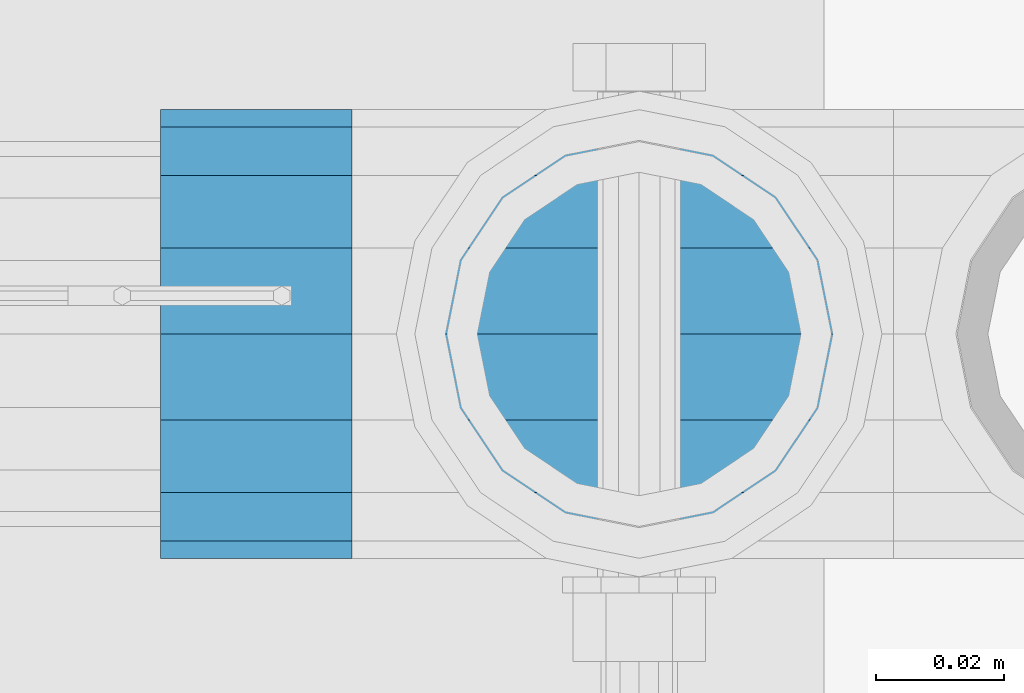
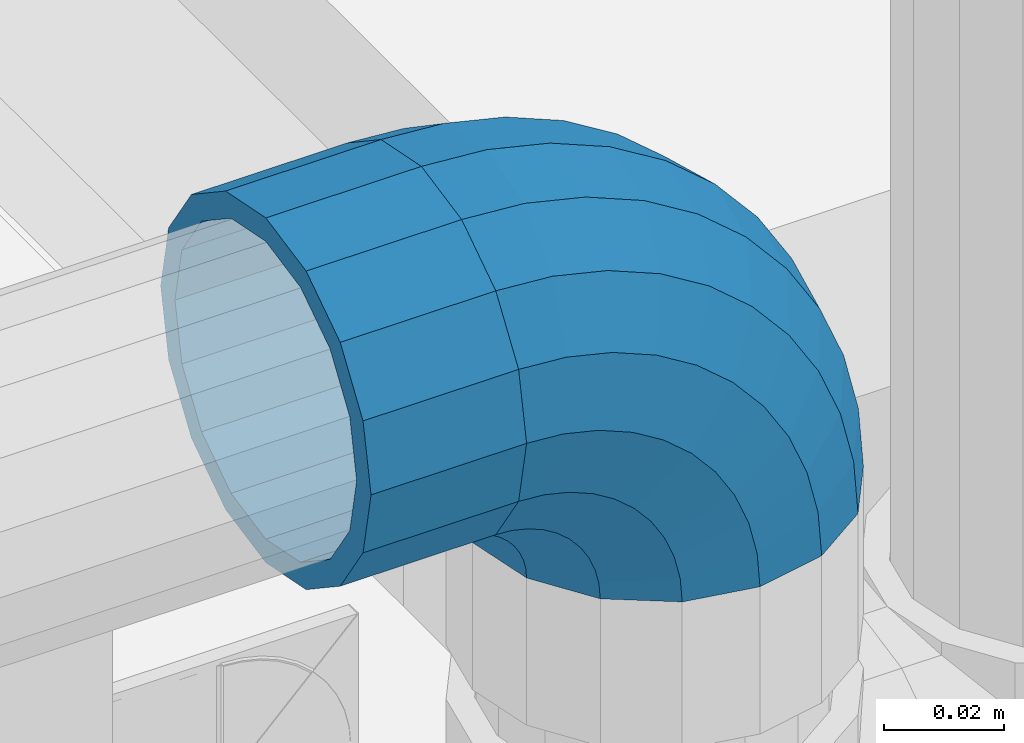
# One storey, part 151 of 219: 1 beam, 1 member.
"""IFC2X3 building model written with IfcOpenShell, lengths in millimetres."""

import ifcopenshell
import ifcopenshell.guid

model = None  # the IFC model being written
_history = None  # IfcOwnerHistory: only IFC2X3 demands one
_inside = {}  # id of a spatial element -> (the spatial element, [elements in it])
_under = {}  # id of a project, library or spatial element -> (it, [spatial elements below it])
_declared = {}  # id of a project -> (the project, [libraries it declares])
_typed = {}  # id of a type object -> (the type object, [elements of that type])
_made_of = {}  # id of a material, layer set ... -> (it, [elements and type objects made of it])


def new_model(schema):
    """Start an empty IFC model of exactly this schema.

    Asked for "IFC4X3", IfcOpenShell would pick the latest addendum, in which some entities
    have other attributes; the version numbers below select the first issue.
    IFC2X3 requires an IfcOwnerHistory on every rooted entity: one is made here for all.
    """
    global model, _history
    if schema == "IFC4X3":
        model = ifcopenshell.file(schema_version=(4, 3, 0, 0))
    else:
        model = ifcopenshell.file(schema=schema)
    _inside.clear()
    _under.clear()
    _declared.clear()
    _typed.clear()
    _made_of.clear()
    _history = None
    if model.schema == "IFC2X3":
        org = make("IfcOrganization", Name="unknown")
        user = make(
            "IfcPersonAndOrganization",
            ThePerson=make("IfcPerson", FamilyName="unknown"),
            TheOrganization=org,
        )
        app = make(
            "IfcApplication",
            ApplicationDeveloper=org,
            Version="unknown",
            ApplicationFullName="unknown",
            ApplicationIdentifier="unknown",
        )
        _history = make(
            "IfcOwnerHistory",
            OwningUser=user,
            OwningApplication=app,
            ChangeAction="ADDED",
            CreationDate=0,
        )
    return model


def make(cls, **values):
    """One entity of the class cls with the attributes given. An attribute that is None is left unset."""
    return model.create_entity(
        cls, **{name: value for name, value in values.items() if value is not None}
    )


def rooted(cls, **values):
    """An entity with a GlobalId (a new one), such as an element, a storey or a relation."""
    return make(cls, GlobalId=ifcopenshell.guid.new(), OwnerHistory=_history, **values)


def si_unit(unit_type, name, prefix=None):
    """IfcSIUnit, for example si_unit("LENGTHUNIT", "METRE", prefix="MILLI")."""
    return make("IfcSIUnit", UnitType=unit_type, Prefix=prefix, Name=name)


def assignment(units):
    """IfcUnitAssignment: the units of a project."""
    return None if units is None else make("IfcUnitAssignment", Units=units)


def point(xyz):
    """IfcCartesianPoint."""
    return None if xyz is None else make("IfcCartesianPoint", Coordinates=xyz)


def direction(xyz):
    """IfcDirection."""
    return None if xyz is None else make("IfcDirection", DirectionRatios=xyz)


def frame(location, z_axis=None, x_axis=None):
    """IfcAxis2Placement3D, a coordinate frame: its origin and axes. An axis left out is left unset."""
    return make(
        "IfcAxis2Placement3D",
        Location=point(location),
        Axis=direction(z_axis),
        RefDirection=direction(x_axis),
    )


def origin_with_axes():
    """The frame at (0, 0, 0) with the z axis (0, 0, 1) and the x axis (1, 0, 0) written out."""
    return frame((0.0, 0.0, 0.0), z_axis=(0.0, 0.0, 1.0), x_axis=(1.0, 0.0, 0.0))


def place(relative_to, where):
    """IfcLocalPlacement: puts the frame where relative to a parent placement (None: the world)."""
    return make(
        "IfcLocalPlacement", PlacementRelTo=relative_to, RelativePlacement=where
    )


def context(
    kind, dimensions, precision=None, world=None, true_north=None, identifier=None
):
    """IfcGeometricRepresentationContext, for example the 3D "Model" context."""
    return make(
        "IfcGeometricRepresentationContext",
        ContextIdentifier=identifier,
        ContextType=kind,
        CoordinateSpaceDimension=dimensions,
        Precision=precision,
        WorldCoordinateSystem=world,
        TrueNorth=true_north,
    )


def subcontext(parent, identifier, kind, view, scale=None):
    """IfcGeometricRepresentationSubContext, for example "Body" below "Model"."""
    return make(
        "IfcGeometricRepresentationSubContext",
        ContextIdentifier=identifier,
        ContextType=kind,
        ParentContext=parent,
        TargetScale=scale,
        TargetView=view,
    )


def project(units=None, contexts=None):
    """IfcProject with its units and contexts."""
    return rooted(
        "IfcProject",
        Name="project",
        RepresentationContexts=contexts,
        UnitsInContext=assignment(units),
    )


def spatial(cls, under=None, at=None, **own):
    """A site, building, storey or space (cls), placed at a placement, below another one or the project."""
    s = rooted(cls, ObjectPlacement=at, **own)
    if under is not None:
        _under.setdefault(under.id(), (under, []))[1].append(s)
    return s


def faces_of(points, faces, orient=None, outer=None):
    """IfcFace entities. A face is a list of loops; a loop is a list of indices into points, from 0.

    orient and outer hold one flag for each loop. By default every Orientation is true, the
    first loop of a face is its IfcFaceOuterBound and the others are IfcFaceBound.
    """
    made = []
    for i, loops in enumerate(faces):
        bounds = []
        for j, loop in enumerate(loops):
            is_outer = j == 0 if outer is None else outer[i][j]
            bounds.append(
                make(
                    "IfcFaceOuterBound" if is_outer else "IfcFaceBound",
                    Bound=make("IfcPolyLoop", Polygon=[points[k] for k in loop]),
                    Orientation=True if orient is None else orient[i][j],
                )
            )
        made.append(make("IfcFace", Bounds=bounds))
    return made


def faceted_brep(points, faces, orient=None, outer=None, voids=None):
    """IfcFacetedBrep: a solid bounded by flat faces; with voids (closed shells), ...WithVoids."""
    shared = [point(p) for p in points]
    hull = make("IfcClosedShell", CfsFaces=faces_of(shared, faces, orient, outer))
    if voids is None:
        return make("IfcFacetedBrep", Outer=hull)
    return make(
        "IfcFacetedBrepWithVoids",
        Outer=hull,
        Voids=[
            make(cls, CfsFaces=faces_of(shared, fs, o, b)) for cls, fs, o, b in voids
        ],
    )


def shape(context_of_items, identifier, shape_type, items):
    """IfcShapeRepresentation: the items that make up one representation, for example the "Body"."""
    return make(
        "IfcShapeRepresentation",
        ContextOfItems=context_of_items,
        RepresentationIdentifier=identifier,
        RepresentationType=shape_type,
        Items=items,
    )


def material(Name=None, Category=None):
    """IfcMaterial."""
    return make("IfcMaterial", Name=Name, Category=Category)


def made_of(thing, what):
    """Note that an element or type object is made of a material, layer set ...; save() writes the relation."""
    if what is not None:
        _made_of.setdefault(what.id(), (what, []))[1].append(thing)
    return thing


def type_object(cls, material=None, **own):
    """A type object (cls), such as IfcWallType, which elements share."""
    return made_of(rooted(cls, **own), material)


def element(
    cls,
    number,
    at=None,
    inside=None,
    cuts=None,
    type_object=None,
    material=None,
    context=None,
    identifier="Body",
    shape_type=None,
    held_by="IfcProductDefinitionShape",
    body=None,
    shapes=None,
    **own,
):
    """One element of the class cls, such as IfcWall. Its Tag is "e" and its number.

    at: its placement. inside: the storey or other place that contains it. cuts: it is an
    opening in that element (IfcRelVoidsElement). A single representation is given by context,
    identifier, shape_type and body (its items); several are given by shapes. held_by: the class
    of the entity that holds the representations. save() writes the other relations.
    """
    e = rooted(cls, Tag="e%d" % number, ObjectPlacement=at, **own)
    if body is not None:
        shapes = [shape(context, identifier, shape_type, body)]
    if shapes is not None:
        e.Representation = make(held_by, Representations=shapes)
    if inside is not None:
        _inside.setdefault(inside.id(), (inside, []))[1].append(e)
    if cuts is not None:
        rooted(
            "IfcRelVoidsElement", RelatingBuildingElement=cuts, RelatedOpeningElement=e
        )
    if type_object is not None:
        _typed.setdefault(type_object.id(), (type_object, []))[1].append(e)
    return made_of(e, material)


def aggregate(whole, parts):
    """IfcRelAggregates: a whole, such as a stair, and the parts it consists of."""
    return rooted("IfcRelAggregates", RelatingObject=whole, RelatedObjects=parts)


def save(model, path):
    """Write the relations noted so far, then the file.

    IfcRelAggregates (storeys below a building ...), IfcRelContainedInSpatialStructure (elements
    in a storey), IfcRelDefinesByType, IfcRelAssociatesMaterial and IfcRelDeclares: one each for
    every whole, place, type object, material and project.
    """
    for whole, parts in _under.values():
        aggregate(whole, parts)
    for where, things in _inside.values():
        rooted(
            "IfcRelContainedInSpatialStructure",
            RelatedElements=things,
            RelatingStructure=where,
        )
    for kind, things in _typed.values():
        rooted("IfcRelDefinesByType", RelatedObjects=things, RelatingType=kind)
    for what, things in _made_of.values():
        rooted("IfcRelAssociatesMaterial", RelatedObjects=things, RelatingMaterial=what)
    for by, libraries in _declared.values():
        rooted("IfcRelDeclares", RelatingContext=by, RelatedDefinitions=libraries)
    model.write(path)


model = new_model("IFC2X3")

# Units and contexts
model_context = context("Model", 3, precision=1e-05, world=origin_with_axes())
body_context = subcontext(model_context, "Body", "Model", "MODEL_VIEW")
ifc_project = project(units=[si_unit("LENGTHUNIT", "METRE", prefix="MILLI"), si_unit("AREAUNIT", "SQUARE_METRE"), si_unit("VOLUMEUNIT", "CUBIC_METRE"), si_unit("MASSUNIT", "GRAM", prefix="KILO"), si_unit("TIMEUNIT", "SECOND"), si_unit("PLANEANGLEUNIT", "RADIAN"), si_unit("SOLIDANGLEUNIT", "STERADIAN"), si_unit("THERMODYNAMICTEMPERATUREUNIT", "DEGREE_CELSIUS"), si_unit("LUMINOUSINTENSITYUNIT", "LUMEN")], contexts=[model_context])

# Site, building, storey
site_placement = place(None, origin_with_axes())
site = spatial("IfcSite", under=ifc_project, at=site_placement, CompositionType="ELEMENT")
building_placement = place(site_placement, origin_with_axes())
building = spatial("IfcBuilding", under=site, at=building_placement, Name="Standard", CompositionType="ELEMENT")
storey_placement = place(building_placement, origin_with_axes())
storey = spatial("IfcBuildingStorey", under=building, at=storey_placement, Name="Undefined", CompositionType="ELEMENT", Elevation=0.0)

# Beam
ifc_material = material(Name="Misc_Undefined")
beam_type = type_object("IfcBeamType", PredefinedType="NOTDEFINED")
beam_placement = place(storey_placement, frame((13386.0, 31664.5, 969.85), z_axis=(0.0, 0.0, 1.0), x_axis=(-1.0, 0.0, 0.0)))
element("IfcBeam", 1, at=beam_placement, inside=storey, type_object=beam_type, material=ifc_material, context=body_context, shape_type="Brep", body=[
    faceted_brep([(0.0, -30.3499999999985, 0.0), (0.0, -28.0397438117179, 11.6144421722802), (30.0, -28.0397438117179, 11.6144421722805), (30.0, -30.3499999999985, 0.0), (0.0, -21.46069080901, 21.4606908090118), (30.0, -21.46069080901, 21.4606908090117), (0.0, -11.614442172282, 28.0397438117179), (30.0, -11.614442172282, 28.0397438117176), (0.0, 0.0, 30.3500000000004), (30.0, 0.0, 30.35), (0.0, 11.614442172282, 28.0397438117179), (30.0, 11.614442172282, 28.0397438117176), (0.0, 21.46069080901, 21.4606908090118), (30.0, 21.46069080901, 21.4606908090117), (0.0, 28.0397438117179, 11.6144421722802), (30.0, 28.0397438117179, 11.6144421722805), (0.0, 30.3499999999985, 0.0), (30.0, 30.3499999999985, 0.0), (0.0, 28.0397438117179, -11.6144421722802), (30.0, 28.0397438117179, -11.6144421722805), (0.0, 21.46069080901, -21.4606908090118), (30.0, 21.46069080901, -21.4606908090117), (0.0, 11.614442172282, -28.0397438117179), (30.0, 11.614442172282, -28.0397438117176), (0.0, 0.0, -30.3500000000004), (30.0, 0.0, -30.35), (0.0, -11.614442172282, -28.0397438117179), (30.0, -11.614442172282, -28.0397438117176), (0.0, -21.46069080901, -21.4606908090118), (30.0, -21.46069080901, -21.4606908090117), (0.0, -28.0397438117179, -11.6144421722802), (30.0, -28.0397438117179, -11.6144421722805), (0.0, -35.1500000000015, 0.0), (0.0, -32.4743655677703, -13.4513226476338), (30.0, -32.4743655677703, -13.4513226476329), (30.0, -35.1500000000015, 0.0), (0.0, -24.8548033587067, -24.8548033587067), (30.0, -24.8548033587067, -24.8548033587072), (0.0, -13.4513226476338, -32.4743655677721), (30.0, -13.4513226476338, -32.4743655677718), (0.0, 0.0, -35.1500000000015), (30.0, 0.0, -35.15), (0.0, 13.4513226476338, -32.4743655677721), (30.0, 13.4513226476338, -32.4743655677718), (0.0, 24.8548033587067, -24.8548033587067), (30.0, 24.8548033587067, -24.8548033587072), (0.0, 32.4743655677703, -13.4513226476338), (30.0, 32.4743655677703, -13.4513226476329), (0.0, 35.1500000000015, 0.0), (30.0, 35.1500000000015, 0.0), (0.0, 32.4743655677703, 13.4513226476338), (30.0, 32.4743655677703, 13.4513226476329), (0.0, 24.8548033587067, 24.8548033587067), (30.0, 24.8548033587067, 24.8548033587072), (0.0, 13.4513226476338, 32.4743655677721), (30.0, 13.4513226476338, 32.4743655677718), (0.0, 0.0, 35.1500000000015), (30.0, 0.0, 35.15), (0.0, -13.4513226476338, 32.4743655677721), (30.0, -13.4513226476338, 32.4743655677718), (0.0, -24.8548033587067, 24.8548033587067), (30.0, -24.8548033587067, 24.8548033587072), (0.0, -32.4743655677703, 13.4513226476338), (30.0, -32.4743655677703, 13.4513226476329)], [[[0, 1, 2, 3]], [[1, 4, 5, 2]], [[4, 6, 7, 5]], [[6, 8, 9, 7]], [[8, 10, 11, 9]], [[10, 12, 13, 11]], [[12, 14, 15, 13]], [[14, 16, 17, 15]], [[16, 18, 19, 17]], [[18, 20, 21, 19]], [[20, 22, 23, 21]], [[22, 24, 25, 23]], [[24, 26, 27, 25]], [[26, 28, 29, 27]], [[28, 30, 31, 29]], [[30, 0, 3, 31]], [[32, 33, 34, 35]], [[33, 36, 37, 34]], [[36, 38, 39, 37]], [[38, 40, 41, 39]], [[40, 42, 43, 41]], [[42, 44, 45, 43]], [[44, 46, 47, 45]], [[46, 48, 49, 47]], [[48, 50, 51, 49]], [[50, 52, 53, 51]], [[52, 54, 55, 53]], [[54, 56, 57, 55]], [[56, 58, 59, 57]], [[58, 60, 61, 59]], [[60, 62, 63, 61]], [[62, 32, 35, 63]], [[37, 39, 41, 43, 45, 47, 49, 51, 53, 55, 57, 59, 61, 63, 35, 34], [5, 7, 9, 11, 13, 15, 17, 19, 21, 23, 25, 27, 29, 31, 3, 2]], [[62, 60, 58, 56, 54, 52, 50, 48, 46, 44, 42, 40, 38, 36, 33, 32], [30, 28, 26, 24, 22, 20, 18, 16, 14, 12, 10, 8, 6, 4, 1, 0]]]),
])

# Member
member_type = type_object("IfcMemberType", PredefinedType="NOTDEFINED")
member_placement = place(storey_placement, frame((13431.0, 31664.5, 924.85), z_axis=(0.707106781186548, 0.0, 0.707106781186547), x_axis=(-0.707106781186548, 0.0, 0.707106781186548)))
element("IfcMember", 2, at=member_placement, inside=storey, type_object=member_type, material=ifc_material, context=body_context, shape_type="Brep", body=[
    faceted_brep([(0.0, -35.1500000000015, 0.0), (9.51152146006825, -32.4743655677703, -9.51152146006643), (13.2759578763371, -32.4743655677703, -6.29638902527404), (5.36946880023152, -35.1500000000015, 4.58595959348168), (17.5749999999971, -24.8548033587067, -17.5749999999971), (19.978755663109, -24.8548033587067, -15.5219987155597), (22.9628441077002, -13.4513226476338, -22.9628441077002), (24.4574219585238, -13.4513226476338, -21.686354032392), (24.8548033587049, 0.0, -24.8548033587031), (26.0301204183133, 0.0, -23.8509877587985), (22.9628441077002, 13.4513226476338, -22.9628441077002), (24.4574219585238, 13.4513226476338, -21.686354032392), (17.5749999999971, 24.8548033587067, -17.5749999999971), (19.978755663109, 24.8548033587067, -15.5219987155597), (9.51152146006825, 32.4743655677703, -9.51152146006643), (13.2759578763371, 32.4743655677703, -6.29638902527404), (0.0, 35.1500000000015, 0.0), (5.36946880023152, 35.1500000000015, 4.58595959348168), (-9.51152146007189, 32.4743655677703, 9.51152146007371), (-2.53702027587497, 32.4743655677703, 15.4683082122356), (-17.5750000000007, 24.8548033587067, 17.5750000000025), (-9.23981806264692, 24.8548033587067, 24.6939179025212), (-22.9628441077039, 13.4513226476338, 22.9628441077057), (-13.718484358059, 13.4513226476338, 30.8582732193536), (-24.8548033587085, 0.0, 24.8548033587103), (-15.2911828178485, 0.0, 33.02290694576), (-22.9628441077039, -13.4513226476338, 22.9628441077057), (-13.718484358059, -13.4513226476338, 30.8582732193536), (-17.5750000000007, -24.8548033587067, 17.5750000000025), (-9.23981806264692, -24.8548033587067, 24.6939179025212), (-9.51152146007189, -32.4743655677703, 9.51152146007371), (-2.53702027587497, -32.4743655677703, 15.4683082122356), (0.0, -30.3499999999985, 0.0), (-8.21265081971978, -28.0397438117179, 8.2126508197216), (-1.45732902223881, -28.0397438117179, 13.9822406910407), (5.36946880023152, -30.3499999999985, 4.58595959348168), (-15.1750000000011, -21.46069080901, 15.1750000000029), (-7.24480876131474, -21.46069080901, 21.9480231689977), (-19.8270929920018, -11.614442172282, 19.8270929920018), (-11.1118790903547, -11.614442172282, 27.2705888550809), (-21.4606908090136, 0.0, 21.4606908090154), (-12.4698136068446, 0.0, 29.1396253727617), (-19.8270929920018, 11.614442172282, 19.8270929920018), (-11.1118790903547, 11.614442172282, 27.2705888550809), (-15.1750000000011, 21.46069080901, 15.1750000000029), (-7.24480876131474, 21.46069080901, 21.9480231689977), (-8.21265081971978, 28.0397438117179, 8.2126508197216), (-1.45732902223881, 28.0397438117179, 13.9822406910407), (0.0, 30.3499999999985, 0.0), (5.36946880023152, 30.3499999999985, 4.58595959348168), (8.21265081971615, 28.0397438117179, -8.21265081971433), (12.1962666227028, 28.0397438117179, -4.81032150407918), (15.1749999999975, 21.46069080901, -15.1749999999975), (17.9837463617769, 21.46069080901, -12.7761039820361), (19.8270929919981, 11.614442172282, -19.8270929919963), (21.8508166908196, 11.614442172282, -18.0986696681193), (21.46069080901, 0.0, -21.4606908090082), (23.2087512073094, 0.0, -19.9677061858001), (19.8270929919981, -11.614442172282, -19.8270929919963), (21.8508166908196, -11.614442172282, -18.0986696681193), (15.1749999999975, -21.46069080901, -15.1749999999975), (17.9837463617769, -21.46069080901, -12.7761039820361), (8.21265081971615, -28.0397438117179, -8.21265081971433), (12.1962666227028, -28.0397438117179, -4.81032150407918), (17.4970053560701, -32.4743655677703, -3.70972780291777), (11.3902326651123, -35.1500000000015, 8.27548843508521), (22.6740772628609, -24.8548033587067, -13.870303514941), (26.1332861179508, -13.4513226476338, -20.6593831546797), (27.3479987309584, 0.0, -23.0433908901377), (26.1332861179508, 13.4513226476338, -20.6593831546797), (22.6740772628609, 24.8548033587067, -13.870303514941), (17.4970053560701, 32.4743655677703, -3.70972780291777), (11.3902326651123, 35.1500000000015, 8.27548843508521), (5.28345997415727, 32.4743655677703, 20.2607046730882), (0.106388067365515, 24.8548033587067, 30.4212803851115), (-3.35282078772343, 13.4513226476338, 37.2103600248465), (-4.56753340073192, 0.0, 39.5943677603063), (-3.35282078772343, -13.4513226476338, 37.2103600248465), (0.106388067365515, -24.8548033587067, 30.4212803851115), (5.28345997415727, -32.4743655677703, 20.2607046730882), (6.11738625912403, -28.0397438117179, 18.6240321853929), (11.3902326651123, -30.3499999999985, 8.27548843508521), (1.64728291997471, -21.46069080901, 27.3971039595035), (-1.33954464053568, -11.614442172282, 33.2590831078942), (-2.38837900198178, 0.0, 35.3175364442013), (-1.33954464053568, 11.614442172282, 33.2590831078942), (1.64728291997471, 21.46069080901, 27.3971039595035), (6.11738625912403, 28.0397438117179, 18.6240321853929), (11.3902326651123, 30.3499999999985, 8.27548843508521), (16.6630790711033, 28.0397438117179, -2.07305531522616), (21.1331824102526, 21.46069080901, -10.8461270893331), (24.1200099707648, 11.614442172282, -16.7081062377274), (25.1688443322091, 0.0, -18.7665595740327), (24.1200099707648, -11.614442172282, -16.7081062377274), (21.1331824102526, -21.46069080901, -10.8461270893331), (16.6630790711033, -28.0397438117179, -2.07305531522616), (22.0707277014599, -32.4743655677703, -1.81522997692991), (17.9140404065201, -35.1500000000015, 10.9777380798878), (25.5945970362091, -24.8548033587067, -12.6605846156435), (27.9491712485078, -13.4513226476338, -19.9072189058916), (28.7759877588005, 0.0, -22.4518984678853), (27.9491712485078, 13.4513226476338, -19.9072189058916), (25.5945970362091, 24.8548033587067, -12.6605846156435), (22.0707277014599, 32.4743655677703, -1.81522997692991), (17.9140404065201, 35.1500000000015, 10.9777380798878), (13.7573531115804, 32.4743655677703, 23.7707061367109), (10.2334837768312, 24.8548033587067, 34.6160607754227), (7.8789095645343, 13.4513226476338, 41.8626950656708), (7.0520930542416, 0.0, 44.4073746276645), (7.8789095645343, -13.4513226476338, 41.8626950656708), (10.2334837768312, -24.8548033587067, 34.6160607754227), (13.7573531115804, -32.4743655677703, 23.7707061367109), (14.3249803951003, -28.0397438117179, 22.023728990971), (17.9140404065201, -30.3499999999985, 10.9777380798878), (11.28232223551, -21.46069080901, 31.3880679179965), (9.24928305077992, -11.614442172282, 37.6451191472715), (8.53537462724125, 0.0, 39.8423033494473), (9.24928305077992, 11.614442172282, 37.6451191472715), (11.28232223551, 21.46069080901, 31.3880679179965), (14.3249803951003, 28.0397438117179, 22.023728990971), (17.9140404065201, 30.3499999999985, 10.9777380798878), (21.5031004179409, 28.0397438117179, -0.0682528311899659), (24.5457585775303, 21.46069080901, -9.43259175821731), (26.5787977622622, 11.614442172282, -15.6896429874923), (27.2927061857999, 0.0, -17.8868271896681), (26.5787977622622, -11.614442172282, -15.6896429874923), (24.5457585775303, -21.46069080901, -9.43259175821731), (21.5031004179409, -28.0397438117179, -0.0682528311899659), (26.8845046890492, -32.4743655677703, -0.659544371261291), (24.7802542265817, -35.1500000000015, 12.6261701733893), (28.6684020936827, -24.8548033587067, -11.9226293117899), (29.8603642316984, -13.4513226476338, -19.4483820661226), (30.2789256727474, 0.0, -22.0910749985305), (29.8603642316984, 13.4513226476338, -19.4483820661226), (28.6684020936827, 24.8548033587067, -11.9226293117899), (26.8845046890492, 32.4743655677703, -0.659544371261291), (24.7802542265817, 35.1500000000015, 12.6261701733893), (22.676003764117, 32.4743655677703, 25.9118847180398), (20.8921063594835, 24.8548033587067, 37.1749696585684), (19.7001442214678, 13.4513226476338, 44.7007224129011), (19.2815827804179, 0.0, 47.343415345309), (19.7001442214678, -13.4513226476338, 44.7007224129011), (20.8921063594835, -24.8548033587067, 37.1749696585684), (22.676003764117, -32.4743655677703, 25.9118847180398), (22.963355178621, -28.0397438117179, 24.0976192894668), (24.7802542265817, -30.3499999999985, 12.6261701733893), (21.4230625404825, -21.46069080901, 33.8226442665673), (20.3938719035323, -11.614442172282, 40.3206982094962), (20.032468212612, 0.0, 42.6025113104515), (20.3938719035323, 11.614442172282, 40.3206982094962), (21.4230625404825, 21.46069080901, 33.8226442665673), (22.963355178621, 28.0397438117179, 24.0976192894668), (24.7802542265817, 30.3499999999985, 12.6261701733893), (26.5971532745452, 28.0397438117179, 1.15472105731169), (28.1374459126837, 21.46069080901, -8.57030391978697), (29.1666365496339, 11.614442172282, -15.0683578627177), (29.5280402405542, 0.0, -17.350170963673), (29.1666365496339, -11.614442172282, -15.0683578627177), (28.1374459126837, -21.46069080901, -8.57030391978697), (26.5971532745434, -28.0397438117179, 1.15472105731169), (31.8198051533936, -32.4743655677703, -0.271127801024704), (31.8198051533927, -35.1500000000015, 13.1801948466091), (31.8198051533927, -24.8548033587067, -11.6746085121013), (31.8198051533927, -13.4513226476338, -19.2941707211648), (31.8198051533918, 0.0, -21.9698051533924), (31.8198051533927, 13.4513226476338, -19.2941707211648), (31.8198051533927, 24.8548033587067, -11.6746085121013), (31.8198051533936, 32.4743655677703, -0.271127801024704), (31.8198051533927, 35.1500000000015, 13.1801948466091), (31.8198051533927, 32.4743655677703, 26.6315174942411), (31.8198051533936, 24.8548033587067, 38.0349982053158), (31.8198051533936, 13.4513226476338, 45.6545604143794), (31.8198051533946, 0.0, 48.3301948466069), (31.8198051533936, -13.4513226476338, 45.6545604143794), (31.8198051533936, -24.8548033587067, 38.0349982053158), (31.8198051533927, -32.4743655677703, 26.6315174942411), (31.8198051533946, -28.0397438117179, 24.7946370188874), (31.8198051533927, -30.3499999999985, 13.1801948466091), (31.8198051533936, -21.46069080901, 34.6408856556191), (31.8198051533927, -11.614442172282, 41.219938658327), (31.8198051533936, 0.0, 43.5301948466076), (31.8198051533927, 11.614442172282, 41.219938658327), (31.8198051533936, 21.46069080901, 34.6408856556191), (31.8198051533946, 28.0397438117179, 24.7946370188874), (31.8198051533927, 30.3499999999985, 13.1801948466091), (31.8198051533918, 28.0397438117179, 1.56575267432709), (31.8198051533918, 21.46069080901, -8.28049596240453), (31.8198051533936, 11.614442172282, -14.8595489651088), (31.8198051533946, 0.0, -17.1698051533931), (31.8198051533936, -11.614442172282, -14.8595489651088), (31.8198051533918, -21.46069080901, -8.28049596240453), (31.8198051533918, -28.0397438117179, 1.56575267432709), (36.755105617739, -32.4743655677703, -0.659544371261291), (38.8593560802037, -35.1500000000015, 12.6261701733893), (34.9712082131036, -24.8548033587067, -11.9226293117918), (33.7792460750888, -13.4513226476338, -19.4483820661226), (33.3606846340399, 0.0, -22.0910749985305), (33.7792460750888, 13.4513226476338, -19.4483820661226), (34.9712082131036, 24.8548033587067, -11.9226293117918), (36.755105617739, 32.4743655677703, -0.659544371261291), (38.8593560802037, 35.1500000000015, 12.6261701733893), (40.9636065426703, 32.4743655677703, 25.9118847180398), (42.7475039473029, 24.8548033587067, 37.1749696585703), (43.9394660853186, 13.4513226476338, 44.7007224129029), (44.3580275263666, 0.0, 47.3434153453072), (43.9394660853186, -13.4513226476338, 44.7007224129029), (42.7475039473029, -24.8548033587067, 37.1749696585703), (40.9636065426703, -32.4743655677703, 25.9118847180398), (40.6762551281663, -28.0397438117179, 24.0976192894668), (38.8593560802037, -30.3499999999985, 12.6261701733893), (42.2165477663048, -21.46069080901, 33.8226442665673), (43.2457384032541, -11.614442172282, 40.3206982094962), (43.6071420941744, 0.0, 42.6025113104515), (43.2457384032541, 11.614442172282, 40.3206982094962), (42.2165477663048, 21.46069080901, 33.8226442665673), (40.6762551281663, 28.0397438117179, 24.0976192894668), (38.8593560802037, 30.3499999999985, 12.6261701733893), (37.0424570322421, 28.0397438117179, 1.15472105731169), (35.5021643941018, 21.46069080901, -8.57030391978878), (34.4729737571524, 11.614442172282, -15.0683578627177), (34.1115700662331, 0.0, -17.350170963673), (34.4729737571524, -11.614442172282, -15.0683578627177), (35.5021643941018, -21.46069080901, -8.57030391978878), (37.0424570322421, -28.0397438117179, 1.15472105731169), (41.5688826053274, -32.4743655677703, -1.81522997692991), (45.7255699002653, -35.1500000000015, 10.9777380798914), (38.0450132705764, -24.8548033587067, -12.6605846156435), (35.6904390582804, -13.4513226476338, -19.9072189058897), (34.8636225479868, 0.0, -22.4518984678853), (35.6904390582804, 13.4513226476338, -19.9072189058897), (38.0450132705764, 24.8548033587067, -12.6605846156435), (41.5688826053274, 32.4743655677703, -1.81522997692991), (45.7255699002653, 35.1500000000015, 10.9777380798914), (49.882257195206, 32.4743655677703, 23.7707061367091), (53.4061265299524, 24.8548033587067, 34.6160607754227), (55.7607007422521, 13.4513226476338, 41.8626950656708), (56.5875172525457, 0.0, 44.4073746276645), (55.7607007422521, -13.4513226476338, 41.8626950656708), (53.4061265299524, -24.8548033587067, 34.6160607754227), (49.882257195206, -32.4743655677703, 23.7707061367091), (49.314629911687, -28.0397438117179, 22.0237289909692), (45.7255699002653, -30.3499999999985, 10.9777380798914), (52.3572880712773, -21.46069080901, 31.3880679179965), (54.3903272560065, -11.614442172282, 37.6451191472715), (55.1042356795451, 0.0, 39.8423033494491), (54.3903272560065, 11.614442172282, 37.6451191472715), (52.3572880712773, 21.46069080901, 31.3880679179965), (49.314629911687, 28.0397438117179, 22.0237289909692), (45.7255699002653, 30.3499999999985, 10.9777380798914), (42.1365098888464, 28.0397438117179, -0.0682528311899659), (39.0938517292561, 21.46069080901, -9.43259175821731), (37.0608125445251, 11.614442172282, -15.6896429874923), (36.3469041209864, 0.0, -17.8868271896699), (37.0608125445251, -11.614442172282, -15.6896429874923), (39.0938517292561, -21.46069080901, -9.43259175821731), (42.1365098888464, -28.0397438117179, -0.0682528311899659), (46.1426049507154, -32.4743655677703, -3.70972780291777), (52.2493776416723, -35.1500000000015, 8.27548843508339), (40.9655330439255, -24.8548033587067, -13.8703035149429), (37.5063241888365, -13.4513226476338, -20.6593831546797), (36.2916115758289, 0.0, -23.0433908901377), (37.5063241888365, 13.4513226476338, -20.6593831546797), (40.9655330439255, 24.8548033587067, -13.8703035149429), (46.1426049507154, 32.4743655677703, -3.70972780291777), (52.2493776416723, 35.1500000000015, 8.27548843508339), (58.35615033263, 32.4743655677703, 20.2607046730882), (63.5332222394209, 24.8548033587067, 30.4212803851115), (66.9924310945089, 13.4513226476338, 37.2103600248465), (68.2071437075174, 0.0, 39.5943677603045), (66.9924310945089, -13.4513226476338, 37.2103600248465), (63.5332222394209, -24.8548033587067, 30.4212803851115), (58.35615033263, -32.4743655677703, 20.2607046730882), (57.5222240476614, -28.0397438117179, 18.6240321853948), (52.2493776416723, -30.3499999999985, 8.27548843508339), (61.9923273868126, -21.46069080901, 27.3971039595035), (64.9791549473239, -11.614442172282, 33.2590831078942), (66.0279893087691, 0.0, 35.3175364442013), (64.9791549473239, 11.614442172282, 33.2590831078942), (61.9923273868126, 21.46069080901, 27.3971039595035), (57.5222240476614, 28.0397438117179, 18.6240321853948), (52.2493776416723, 30.3499999999985, 8.27548843508339), (46.976531235684, 28.0397438117179, -2.07305531522616), (42.5064278965338, 21.46069080901, -10.8461270893331), (39.5196003360215, 11.614442172282, -16.7081062377274), (38.4707659745773, 0.0, -18.7665595740309), (39.5196003360215, -11.614442172282, -16.7081062377274), (42.5064278965338, -21.46069080901, -10.8461270893331), (46.976531235684, -28.0397438117179, -2.07305531522616), (50.3636524304493, -32.4743655677703, -6.29638902527586), (58.2701415065549, -35.1500000000015, 4.58595959347986), (43.6608546436764, -24.8548033587067, -15.5219987155615), (39.1821883482644, -13.4513226476338, -21.686354032392), (37.6094898884739, 0.0, -23.8509877587985), (39.1821883482644, 13.4513226476338, -21.686354032392), (43.6608546436764, 24.8548033587067, -15.5219987155615), (50.3636524304493, 32.4743655677703, -6.29638902527586), (58.2701415065549, 35.1500000000015, 4.58595959347986), (66.1766305826604, 32.4743655677703, 15.4683082122374), (72.8794283694315, 24.8548033587067, 24.6939179025212), (77.3580946648453, 13.4513226476338, 30.8582732193536), (78.9307931246358, 0.0, 33.02290694576), (77.3580946648453, -13.4513226476338, 30.8582732193536), (72.8794283694315, -24.8548033587067, 24.6939179025212), (66.1766305826604, -32.4743655677703, 15.4683082122374), (65.0969393290261, -28.0397438117179, 13.9822406910407), (58.2701415065549, -30.3499999999985, 4.58595959347986), (70.8844190681011, -21.46069080901, 21.9480231689959), (74.7514893971411, -11.614442172282, 27.2705888550809), (76.109423913631, 0.0, 29.139625372758), (74.7514893971411, 11.614442172282, 27.2705888550809), (70.8844190681011, 21.46069080901, 21.9480231689959), (65.0969393290261, 28.0397438117179, 13.9822406910407), (58.2701415065549, 30.3499999999985, 4.58595959347986), (51.4433436840836, 28.0397438117179, -4.810321504081), (45.6558639450086, 21.46069080901, -12.7761039820361), (41.7887936159668, 11.614442172282, -18.0986696681193), (40.4308590994788, 0.0, -19.9677061858001), (41.7887936159668, -11.614442172282, -18.0986696681193), (45.6558639450086, -21.46069080901, -12.7761039820361), (51.4433436840836, -28.0397438117179, -4.810321504081), (54.1280888467181, -32.4743655677703, -9.51152146006643), (63.6396103067882, -35.1500000000015, 3.63797880709171e-12), (46.0646103067875, -24.8548033587067, -17.5749999999971), (40.6767661990853, -13.4513226476338, -22.9628441077002), (38.7848069480806, 0.0, -24.8548033587049), (40.6767661990853, 13.4513226476338, -22.9628441077002), (46.0646103067875, 24.8548033587067, -17.5749999999971), (54.1280888467181, 32.4743655677703, -9.51152146006643), (63.6396103067882, 35.1500000000015, 3.63797880709171e-12), (73.1511317668574, 32.4743655677703, 9.51152146007189), (81.214610306788, 24.8548033587067, 17.5750000000025), (86.6024544144902, 13.4513226476338, 22.9628441077057), (88.4944136654949, 0.0, 24.8548033587103), (86.6024544144902, -13.4513226476338, 22.9628441077057), (81.214610306788, -24.8548033587067, 17.5750000000025), (73.1511317668574, -32.4743655677703, 9.51152146007189), (71.8522611265062, -28.0397438117179, 8.2126508197216), (63.6396103067882, -30.3499999999985, 3.63797880709171e-12), (78.8146103067875, -21.46069080901, 15.1750000000029), (83.4667032987863, -11.614442172282, 19.8270929920018), (85.1003011158, 0.0, 21.4606908090154), (83.4667032987863, 11.614442172282, 19.8270929920018), (78.8146103067875, 21.46069080901, 15.1750000000029), (71.8522611265062, 28.0397438117179, 8.2126508197216), (63.6396103067882, 30.3499999999985, 3.63797880709171e-12), (55.4269594870693, 28.0397438117179, -8.21265081971615), (48.464610306788, 21.46069080901, -15.1749999999975), (43.8125173147882, 11.614442172282, -19.8270929919963), (42.1789194977764, 0.0, -21.4606908090082), (43.8125173147882, -11.614442172282, -19.8270929919963), (48.464610306788, -21.46069080901, -15.1749999999975), (55.4269594870693, -28.0397438117179, -8.21265081971615)], [[[0, 1, 2, 3]], [[1, 4, 5, 2]], [[4, 6, 7, 5]], [[6, 8, 9, 7]], [[8, 10, 11, 9]], [[10, 12, 13, 11]], [[12, 14, 15, 13]], [[14, 16, 17, 15]], [[16, 18, 19, 17]], [[18, 20, 21, 19]], [[20, 22, 23, 21]], [[22, 24, 25, 23]], [[24, 26, 27, 25]], [[26, 28, 29, 27]], [[28, 30, 31, 29]], [[30, 0, 3, 31]], [[32, 33, 34, 35]], [[33, 36, 37, 34]], [[36, 38, 39, 37]], [[38, 40, 41, 39]], [[40, 42, 43, 41]], [[42, 44, 45, 43]], [[44, 46, 47, 45]], [[46, 48, 49, 47]], [[48, 50, 51, 49]], [[50, 52, 53, 51]], [[52, 54, 55, 53]], [[54, 56, 57, 55]], [[56, 58, 59, 57]], [[58, 60, 61, 59]], [[60, 62, 63, 61]], [[62, 32, 35, 63]], [[30, 28, 26, 24, 22, 20, 18, 16, 14, 12, 10, 8, 6, 4, 1, 0], [62, 60, 58, 56, 54, 52, 50, 48, 46, 44, 42, 40, 38, 36, 33, 32]], [[3, 2, 64, 65]], [[2, 5, 66, 64]], [[5, 7, 67, 66]], [[7, 9, 68, 67]], [[9, 11, 69, 68]], [[11, 13, 70, 69]], [[13, 15, 71, 70]], [[15, 17, 72, 71]], [[17, 19, 73, 72]], [[19, 21, 74, 73]], [[21, 23, 75, 74]], [[23, 25, 76, 75]], [[25, 27, 77, 76]], [[27, 29, 78, 77]], [[29, 31, 79, 78]], [[31, 3, 65, 79]], [[35, 34, 80, 81]], [[34, 37, 82, 80]], [[37, 39, 83, 82]], [[39, 41, 84, 83]], [[41, 43, 85, 84]], [[43, 45, 86, 85]], [[45, 47, 87, 86]], [[47, 49, 88, 87]], [[49, 51, 89, 88]], [[51, 53, 90, 89]], [[53, 55, 91, 90]], [[55, 57, 92, 91]], [[57, 59, 93, 92]], [[59, 61, 94, 93]], [[61, 63, 95, 94]], [[63, 35, 81, 95]], [[65, 64, 96, 97]], [[64, 66, 98, 96]], [[66, 67, 99, 98]], [[67, 68, 100, 99]], [[68, 69, 101, 100]], [[69, 70, 102, 101]], [[70, 71, 103, 102]], [[71, 72, 104, 103]], [[72, 73, 105, 104]], [[73, 74, 106, 105]], [[74, 75, 107, 106]], [[75, 76, 108, 107]], [[76, 77, 109, 108]], [[77, 78, 110, 109]], [[78, 79, 111, 110]], [[79, 65, 97, 111]], [[81, 80, 112, 113]], [[80, 82, 114, 112]], [[82, 83, 115, 114]], [[83, 84, 116, 115]], [[84, 85, 117, 116]], [[85, 86, 118, 117]], [[86, 87, 119, 118]], [[87, 88, 120, 119]], [[88, 89, 121, 120]], [[89, 90, 122, 121]], [[90, 91, 123, 122]], [[91, 92, 124, 123]], [[92, 93, 125, 124]], [[93, 94, 126, 125]], [[94, 95, 127, 126]], [[95, 81, 113, 127]], [[97, 96, 128, 129]], [[96, 98, 130, 128]], [[98, 99, 131, 130]], [[99, 100, 132, 131]], [[100, 101, 133, 132]], [[101, 102, 134, 133]], [[102, 103, 135, 134]], [[103, 104, 136, 135]], [[104, 105, 137, 136]], [[105, 106, 138, 137]], [[106, 107, 139, 138]], [[107, 108, 140, 139]], [[108, 109, 141, 140]], [[109, 110, 142, 141]], [[110, 111, 143, 142]], [[111, 97, 129, 143]], [[113, 112, 144, 145]], [[112, 114, 146, 144]], [[114, 115, 147, 146]], [[115, 116, 148, 147]], [[116, 117, 149, 148]], [[117, 118, 150, 149]], [[118, 119, 151, 150]], [[119, 120, 152, 151]], [[120, 121, 153, 152]], [[121, 122, 154, 153]], [[122, 123, 155, 154]], [[123, 124, 156, 155]], [[124, 125, 157, 156]], [[125, 126, 158, 157]], [[126, 127, 159, 158]], [[127, 113, 145, 159]], [[129, 128, 160, 161]], [[128, 130, 162, 160]], [[130, 131, 163, 162]], [[131, 132, 164, 163]], [[132, 133, 165, 164]], [[133, 134, 166, 165]], [[134, 135, 167, 166]], [[135, 136, 168, 167]], [[136, 137, 169, 168]], [[137, 138, 170, 169]], [[138, 139, 171, 170]], [[139, 140, 172, 171]], [[140, 141, 173, 172]], [[141, 142, 174, 173]], [[142, 143, 175, 174]], [[143, 129, 161, 175]], [[145, 144, 176, 177]], [[144, 146, 178, 176]], [[146, 147, 179, 178]], [[147, 148, 180, 179]], [[148, 149, 181, 180]], [[149, 150, 182, 181]], [[150, 151, 183, 182]], [[151, 152, 184, 183]], [[152, 153, 185, 184]], [[153, 154, 186, 185]], [[154, 155, 187, 186]], [[155, 156, 188, 187]], [[156, 157, 189, 188]], [[157, 158, 190, 189]], [[158, 159, 191, 190]], [[159, 145, 177, 191]], [[161, 160, 192, 193]], [[160, 162, 194, 192]], [[162, 163, 195, 194]], [[163, 164, 196, 195]], [[164, 165, 197, 196]], [[165, 166, 198, 197]], [[166, 167, 199, 198]], [[167, 168, 200, 199]], [[168, 169, 201, 200]], [[169, 170, 202, 201]], [[170, 171, 203, 202]], [[171, 172, 204, 203]], [[172, 173, 205, 204]], [[173, 174, 206, 205]], [[174, 175, 207, 206]], [[175, 161, 193, 207]], [[177, 176, 208, 209]], [[176, 178, 210, 208]], [[178, 179, 211, 210]], [[179, 180, 212, 211]], [[180, 181, 213, 212]], [[181, 182, 214, 213]], [[182, 183, 215, 214]], [[183, 184, 216, 215]], [[184, 185, 217, 216]], [[185, 186, 218, 217]], [[186, 187, 219, 218]], [[187, 188, 220, 219]], [[188, 189, 221, 220]], [[189, 190, 222, 221]], [[190, 191, 223, 222]], [[191, 177, 209, 223]], [[193, 192, 224, 225]], [[192, 194, 226, 224]], [[194, 195, 227, 226]], [[195, 196, 228, 227]], [[196, 197, 229, 228]], [[197, 198, 230, 229]], [[198, 199, 231, 230]], [[199, 200, 232, 231]], [[200, 201, 233, 232]], [[201, 202, 234, 233]], [[202, 203, 235, 234]], [[203, 204, 236, 235]], [[204, 205, 237, 236]], [[205, 206, 238, 237]], [[206, 207, 239, 238]], [[207, 193, 225, 239]], [[209, 208, 240, 241]], [[208, 210, 242, 240]], [[210, 211, 243, 242]], [[211, 212, 244, 243]], [[212, 213, 245, 244]], [[213, 214, 246, 245]], [[214, 215, 247, 246]], [[215, 216, 248, 247]], [[216, 217, 249, 248]], [[217, 218, 250, 249]], [[218, 219, 251, 250]], [[219, 220, 252, 251]], [[220, 221, 253, 252]], [[221, 222, 254, 253]], [[222, 223, 255, 254]], [[223, 209, 241, 255]], [[225, 224, 256, 257]], [[224, 226, 258, 256]], [[226, 227, 259, 258]], [[227, 228, 260, 259]], [[228, 229, 261, 260]], [[229, 230, 262, 261]], [[230, 231, 263, 262]], [[231, 232, 264, 263]], [[232, 233, 265, 264]], [[233, 234, 266, 265]], [[234, 235, 267, 266]], [[235, 236, 268, 267]], [[236, 237, 269, 268]], [[237, 238, 270, 269]], [[238, 239, 271, 270]], [[239, 225, 257, 271]], [[241, 240, 272, 273]], [[240, 242, 274, 272]], [[242, 243, 275, 274]], [[243, 244, 276, 275]], [[244, 245, 277, 276]], [[245, 246, 278, 277]], [[246, 247, 279, 278]], [[247, 248, 280, 279]], [[248, 249, 281, 280]], [[249, 250, 282, 281]], [[250, 251, 283, 282]], [[251, 252, 284, 283]], [[252, 253, 285, 284]], [[253, 254, 286, 285]], [[254, 255, 287, 286]], [[255, 241, 273, 287]], [[257, 256, 288, 289]], [[256, 258, 290, 288]], [[258, 259, 291, 290]], [[259, 260, 292, 291]], [[260, 261, 293, 292]], [[261, 262, 294, 293]], [[262, 263, 295, 294]], [[263, 264, 296, 295]], [[264, 265, 297, 296]], [[265, 266, 298, 297]], [[266, 267, 299, 298]], [[267, 268, 300, 299]], [[268, 269, 301, 300]], [[269, 270, 302, 301]], [[270, 271, 303, 302]], [[271, 257, 289, 303]], [[273, 272, 304, 305]], [[272, 274, 306, 304]], [[274, 275, 307, 306]], [[275, 276, 308, 307]], [[276, 277, 309, 308]], [[277, 278, 310, 309]], [[278, 279, 311, 310]], [[279, 280, 312, 311]], [[280, 281, 313, 312]], [[281, 282, 314, 313]], [[282, 283, 315, 314]], [[283, 284, 316, 315]], [[284, 285, 317, 316]], [[285, 286, 318, 317]], [[286, 287, 319, 318]], [[287, 273, 305, 319]], [[289, 288, 320, 321]], [[288, 290, 322, 320]], [[290, 291, 323, 322]], [[291, 292, 324, 323]], [[292, 293, 325, 324]], [[293, 294, 326, 325]], [[294, 295, 327, 326]], [[295, 296, 328, 327]], [[296, 297, 329, 328]], [[297, 298, 330, 329]], [[298, 299, 331, 330]], [[299, 300, 332, 331]], [[300, 301, 333, 332]], [[301, 302, 334, 333]], [[302, 303, 335, 334]], [[303, 289, 321, 335]], [[305, 304, 336, 337]], [[304, 306, 338, 336]], [[306, 307, 339, 338]], [[307, 308, 340, 339]], [[308, 309, 341, 340]], [[309, 310, 342, 341]], [[310, 311, 343, 342]], [[311, 312, 344, 343]], [[312, 313, 345, 344]], [[313, 314, 346, 345]], [[314, 315, 347, 346]], [[315, 316, 348, 347]], [[316, 317, 349, 348]], [[317, 318, 350, 349]], [[318, 319, 351, 350]], [[319, 305, 337, 351]], [[322, 323, 324, 325, 326, 327, 328, 329, 330, 331, 332, 333, 334, 335, 321, 320], [338, 339, 340, 341, 342, 343, 344, 345, 346, 347, 348, 349, 350, 351, 337, 336]]]),
])

save(model, "model.ifc")
